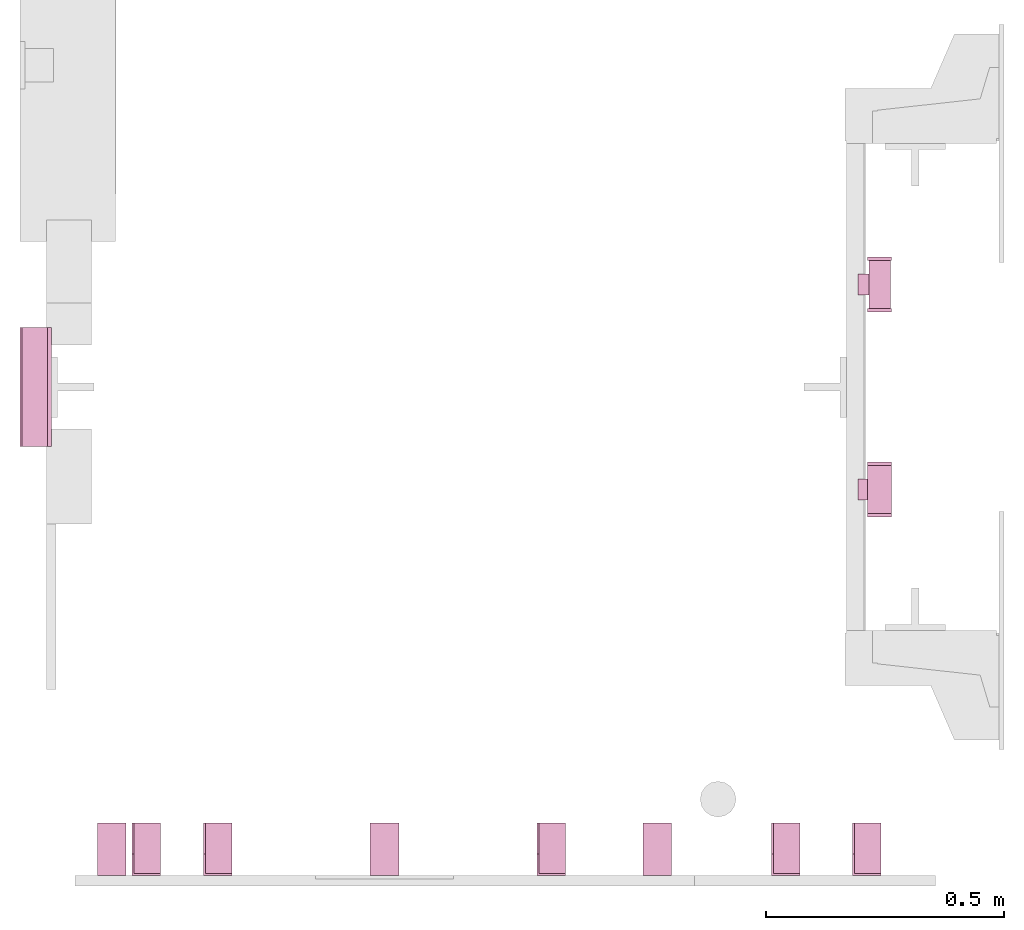
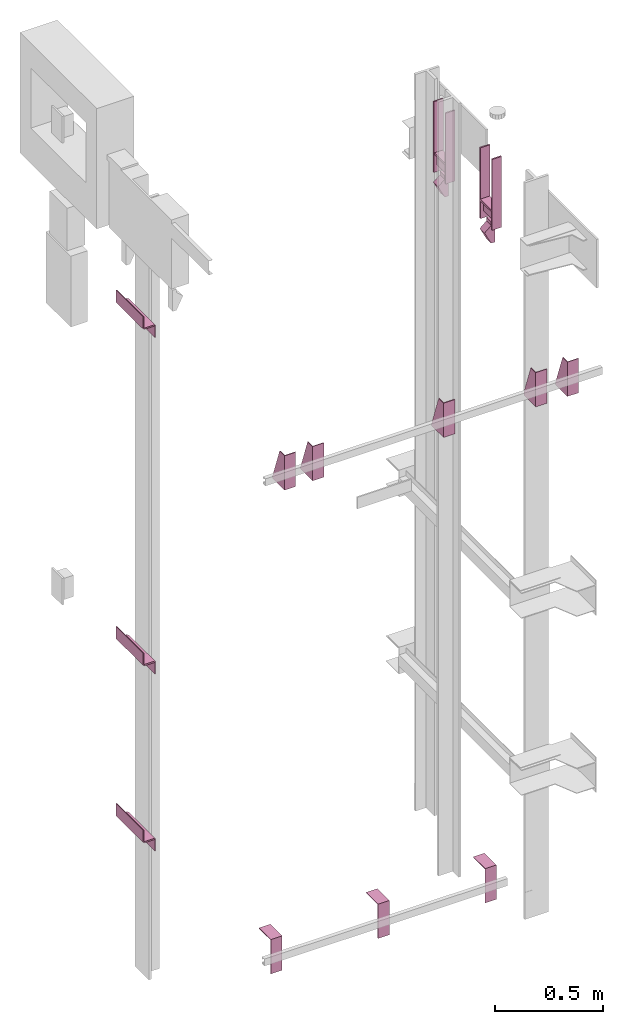
# One storey, part 4 of 4: 12 transport elements.
"""IFC4 building model written with IfcOpenShell, lengths in millimetres."""

from ifc_helpers import new_model, entity, si_unit, converted_unit, frame, origin_with_axes, place, context, subcontext, project, spatial, faceted_brep, element, save


model = new_model("IFC4")

# Units and contexts
context_of_model = context(None, 3, precision=0.01, world=origin_with_axes())
sub_context_1 = subcontext(context_of_model, None, None, "MODEL_VIEW")
sub_context_2 = subcontext(context_of_model, None, None, "MODEL_VIEW")
sub_context_3 = subcontext(context_of_model, None, None, "MODEL_VIEW")
sub_context_4 = subcontext(context_of_model, None, None, "MODEL_VIEW")
sub_context_5 = subcontext(context_of_model, None, None, "MODEL_VIEW")
sub_context_6 = subcontext(context_of_model, None, None, "MODEL_VIEW")
sub_context_7 = subcontext(context_of_model, None, None, "MODEL_VIEW")
sub_context_8 = subcontext(context_of_model, None, None, "MODEL_VIEW")
sub_context_9 = subcontext(context_of_model, None, None, "MODEL_VIEW")
sub_context_10 = subcontext(context_of_model, None, None, "MODEL_VIEW")
sub_context_11 = subcontext(context_of_model, None, None, "MODEL_VIEW")
sub_context_12 = subcontext(context_of_model, None, None, "MODEL_VIEW")
ifc_project = project(units=[converted_unit("PLANEANGLEUNIT", "degree", entity("IfcPlaneAngleMeasure", 0.017453292519943), si_unit("PLANEANGLEUNIT", "RADIAN"), dimensions=[0, 0, 0, 0, 0, 0, 0]), si_unit("LENGTHUNIT", "METRE", prefix="MILLI"), si_unit("MASSUNIT", "GRAM", prefix="KILO"), converted_unit("TIMEUNIT", "year", entity("IfcTimeMeasure", 31557600.0), si_unit("TIMEUNIT", "SECOND"), dimensions=[0, 0, 1, 0, 0, 0, 0]), si_unit("THERMODYNAMICTEMPERATUREUNIT", "DEGREE_CELSIUS"), si_unit("AREAUNIT", "SQUARE_METRE"), si_unit("FORCEUNIT", "NEWTON"), si_unit("VOLUMEUNIT", "CUBIC_METRE"), si_unit("PRESSUREUNIT", "PASCAL"), si_unit("SOLIDANGLEUNIT", "STERADIAN")], contexts=[context_of_model])

# Site, building, storey
site = spatial("IfcSite", under=ifc_project)
building = spatial("IfcBuilding", under=site, Name="Document")
placement = place(None, origin_with_axes())
storey_placement = place(placement, frame((0.0, 0.0, 4420.0), z_axis=(0.0, 0.0, 1.0), x_axis=(1.0, 0.0, 0.0)))
storey = spatial("IfcBuildingStorey", under=building, at=storey_placement, Name="1", Elevation=4420.0)

# Transport elements
transport_element_1_placement = place(storey_placement, frame((1804.0, 810.0, 2854.0), z_axis=(0.0, 0.0, 1.0), x_axis=(1.0, 0.0, 0.0)))
element("IfcTransportElement", 1, at=transport_element_1_placement, inside=storey, PredefinedType="ELEVATOR", context=sub_context_1, shape_type="Brep", body=[
    faceted_brep([(-25.0, 480.0, 100.0), (-25.0, 488.0, 100.0), (25.0, 488.0, 100.0), (25.0, 480.0, 100.0), (-25.0, 480.0, 500.0), (25.0, 480.0, 500.0), (25.0, 488.0, 500.0), (-25.0, 488.0, 500.0)], [[[0, 1, 2, 3]], [[4, 5, 6, 7]], [[0, 3, 5, 4]], [[3, 2, 6, 5]], [[2, 1, 7, 6]], [[1, 0, 4, 7]]]),
    faceted_brep([(10.0, 452.0, 0.0), (10.0, 452.0, 120.0), (10.0, 408.0, 120.0), (10.0, 408.0, 0.0), (-10.0, 408.0, 120.0), (-10.0, 452.0, 120.0), (-10.0, 452.0, 100.0), (-10.0, 408.0, 100.0), (-45.0, 408.0, 70.0), (-45.0, 452.0, 70.0), (-10.0, 452.0, 0.0), (-10.0, 408.0, 0.0)], [[[0, 1, 2, 3]], [[4, 5, 6, 7]], [[8, 9, 10, 11]], [[7, 6, 9, 8]], [[3, 2, 4, 7, 8, 11]], [[9, 6, 5, 1, 0, 10]], [[10, 0, 3, 11]], [[2, 1, 5, 4]]]),
    faceted_brep([(22.5, 480.0, 200.0), (22.5, 480.0, 211.0), (22.5, 380.0, 211.0), (22.5, 380.0, 200.0), (-22.5, 480.0, 200.0), (-22.5, 380.0, 200.0), (-22.5, 380.0, 211.0), (-22.5, 480.0, 211.0)], [[[0, 1, 2, 3]], [[4, 5, 6, 7]], [[0, 3, 5, 4]], [[3, 2, 6, 5]], [[2, 1, 7, 6]], [[1, 0, 4, 7]]]),
    faceted_brep([(25.0, 50.0, 200.0), (25.0, 50.0, 211.0), (25.0, -50.0, 211.0), (25.0, -50.0, 200.0), (-25.0, 50.0, 200.0), (-25.0, -50.0, 200.0), (-25.0, -50.0, 211.0), (-25.0, 50.0, 211.0)], [[[0, 1, 2, 3]], [[4, 5, 6, 7]], [[0, 3, 5, 4]], [[3, 2, 6, 5]], [[2, 1, 7, 6]], [[1, 0, 4, 7]]]),
    faceted_brep([(-25.0, -58.0, 100.0), (-25.0, -50.0, 100.0), (25.0, -50.0, 100.0), (25.0, -58.0, 100.0), (-25.0, -58.0, 500.0), (25.0, -58.0, 500.0), (25.0, -50.0, 500.0), (-25.0, -50.0, 500.0)], [[[0, 1, 2, 3]], [[4, 5, 6, 7]], [[0, 3, 5, 4]], [[3, 2, 6, 5]], [[2, 1, 7, 6]], [[1, 0, 4, 7]]]),
    faceted_brep([(10.0, 480.0, 140.0), (10.0, 480.0, 200.0), (10.0, 380.0, 200.0), (10.0, 380.0, 140.0), (-10.0, 480.0, 140.0), (-10.0, 380.0, 140.0), (-10.0, 380.0, 200.0), (-10.0, 480.0, 200.0)], [[[0, 1, 2, 3]], [[4, 5, 6, 7]], [[0, 3, 5, 4]], [[3, 2, 6, 5]], [[2, 1, 7, 6]], [[1, 0, 4, 7]]]),
    faceted_brep([(10.0, 22.0, 0.0), (10.0, 22.0, 120.0), (10.0, -22.0, 120.0), (10.0, -22.0, 0.0), (-10.0, -22.0, 120.0), (-10.0, 22.0, 120.0), (-10.0, 22.0, 100.0), (-10.0, -22.0, 100.0), (-45.0, -22.0, 70.0), (-45.0, 22.0, 70.0), (-10.0, 22.0, 0.0), (-10.0, -22.0, 0.0)], [[[0, 1, 2, 3]], [[4, 5, 6, 7]], [[8, 9, 10, 11]], [[7, 6, 9, 8]], [[3, 2, 4, 7, 8, 11]], [[9, 6, 5, 1, 0, 10]], [[10, 0, 3, 11]], [[2, 1, 5, 4]]]),
    faceted_brep([(-25.0, 50.0, 100.0), (-25.0, 58.0, 100.0), (25.0, 58.0, 100.0), (25.0, 50.0, 100.0), (-25.0, 50.0, 500.0), (25.0, 50.0, 500.0), (25.0, 58.0, 500.0), (-25.0, 58.0, 500.0)], [[[0, 1, 2, 3]], [[4, 5, 6, 7]], [[0, 3, 5, 4]], [[3, 2, 6, 5]], [[2, 1, 7, 6]], [[1, 0, 4, 7]]]),
    faceted_brep([(-25.0, 372.0, 100.0), (-25.0, 380.0, 100.0), (25.0, 380.0, 100.0), (25.0, 372.0, 100.0), (-25.0, 372.0, 500.0), (25.0, 372.0, 500.0), (25.0, 380.0, 500.0), (-25.0, 380.0, 500.0)], [[[0, 1, 2, 3]], [[4, 5, 6, 7]], [[0, 3, 5, 4]], [[3, 2, 6, 5]], [[2, 1, 7, 6]], [[1, 0, 4, 7]]]),
    faceted_brep([(10.0, 50.0, 140.0), (10.0, 50.0, 200.0), (10.0, -50.0, 200.0), (10.0, -50.0, 140.0), (-10.0, 50.0, 140.0), (-10.0, -50.0, 140.0), (-10.0, -50.0, 200.0), (-10.0, 50.0, 200.0)], [[[0, 1, 2, 3]], [[4, 5, 6, 7]], [[0, 3, 5, 4]], [[3, 2, 6, 5]], [[2, 1, 7, 6]], [[1, 0, 4, 7]]]),
])
transport_element_2_placement = place(storey_placement, frame((265.0, 0.0, 2580.0), z_axis=(0.0, 0.0, 1.0), x_axis=(1.0, 0.0, 0.0)))
element("IfcTransportElement", 2, at=transport_element_2_placement, inside=storey, PredefinedType="ELEVATOR", context=sub_context_2, shape_type="Brep", body=[
    faceted_brep([(-30.0, 0.0, -97.0), (-30.0, 0.0, 97.0), (-30.0, 4.0, 97.0), (-30.0, 4.0, -93.0), (-30.0, 110.0, -93.0), (-30.0, 110.0, -97.0), (30.0, 110.0, -97.0), (30.0, 110.0, -93.0), (30.0, 4.0, -93.0), (30.0, 4.0, 97.0), (30.0, 0.0, 97.0), (30.0, 0.0, -97.0)], [[[0, 1, 2, 3, 4, 5]], [[6, 7, 8, 9, 10, 11]], [[11, 10, 1, 0]], [[2, 9, 8, 3]], [[4, 7, 6, 5]], [[5, 6, 11, 0]], [[8, 7, 4, 3]], [[10, 9, 2, 1]]]),
    faceted_brep([(-30.0, 4.0, -93.0), (-30.0, 4.0, 97.0), (-30.0, 45.0, 97.0), (-30.0, 110.0, -82.0), (-30.0, 110.0, -93.0), (-26.0, 4.0, -93.0), (-26.0, 110.0, -93.0), (-26.0, 110.0, -82.0), (-26.0, 45.0, 97.0), (-26.0, 4.0, 97.0)], [[[0, 1, 2, 3, 4]], [[5, 6, 7, 8, 9]], [[5, 0, 4, 6]], [[6, 4, 3, 7]], [[7, 3, 2, 8]], [[8, 2, 1, 9]], [[9, 1, 0, 5]]]),
])
transport_element_3_placement = place(storey_placement, frame((415.0, 0.0, 2580.0), z_axis=(0.0, 0.0, 1.0), x_axis=(1.0, 0.0, 0.0)))
element("IfcTransportElement", 3, at=transport_element_3_placement, inside=storey, PredefinedType="ELEVATOR", context=sub_context_3, shape_type="Brep", body=[
    faceted_brep([(-30.0, 0.0, -97.0), (-30.0, 0.0, 97.0), (-30.0, 4.0, 97.0), (-30.0, 4.0, -93.0), (-30.0, 110.0, -93.0), (-30.0, 110.0, -97.0), (30.0, 110.0, -97.0), (30.0, 110.0, -93.0), (30.0, 4.0, -93.0), (30.0, 4.0, 97.0), (30.0, 0.0, 97.0), (30.0, 0.0, -97.0)], [[[0, 1, 2, 3, 4, 5]], [[6, 7, 8, 9, 10, 11]], [[11, 10, 1, 0]], [[2, 9, 8, 3]], [[4, 7, 6, 5]], [[5, 6, 11, 0]], [[8, 7, 4, 3]], [[10, 9, 2, 1]]]),
    faceted_brep([(-30.0, 4.0, -93.0), (-30.0, 4.0, 97.0), (-30.0, 45.0, 97.0), (-30.0, 110.0, -82.0), (-30.0, 110.0, -93.0), (-26.0, 4.0, -93.0), (-26.0, 110.0, -93.0), (-26.0, 110.0, -82.0), (-26.0, 45.0, 97.0), (-26.0, 4.0, 97.0)], [[[0, 1, 2, 3, 4]], [[5, 6, 7, 8, 9]], [[5, 0, 4, 6]], [[6, 4, 3, 7]], [[7, 3, 2, 8]], [[8, 2, 1, 9]], [[9, 1, 0, 5]]]),
])
transport_element_4_placement = place(storey_placement, frame((1115.0, 0.0, 2580.0), z_axis=(0.0, 0.0, 1.0), x_axis=(1.0, 0.0, 0.0)))
element("IfcTransportElement", 4, at=transport_element_4_placement, inside=storey, PredefinedType="ELEVATOR", context=sub_context_4, shape_type="Brep", body=[
    faceted_brep([(-30.0, 4.0, -93.0), (-30.0, 4.0, 97.0), (-30.0, 45.0, 97.0), (-30.0, 110.0, -82.0), (-30.0, 110.0, -93.0), (-26.0, 4.0, -93.0), (-26.0, 110.0, -93.0), (-26.0, 110.0, -82.0), (-26.0, 45.0, 97.0), (-26.0, 4.0, 97.0)], [[[0, 1, 2, 3, 4]], [[5, 6, 7, 8, 9]], [[5, 0, 4, 6]], [[6, 4, 3, 7]], [[7, 3, 2, 8]], [[8, 2, 1, 9]], [[9, 1, 0, 5]]]),
    faceted_brep([(-30.0, 0.0, -97.0), (-30.0, 0.0, 97.0), (-30.0, 4.0, 97.0), (-30.0, 4.0, -93.0), (-30.0, 110.0, -93.0), (-30.0, 110.0, -97.0), (30.0, 110.0, -97.0), (30.0, 110.0, -93.0), (30.0, 4.0, -93.0), (30.0, 4.0, 97.0), (30.0, 0.0, 97.0), (30.0, 0.0, -97.0)], [[[0, 1, 2, 3, 4, 5]], [[6, 7, 8, 9, 10, 11]], [[11, 10, 1, 0]], [[2, 9, 8, 3]], [[4, 7, 6, 5]], [[5, 6, 11, 0]], [[8, 7, 4, 3]], [[10, 9, 2, 1]]]),
])
transport_element_5_placement = place(storey_placement, frame((1607.0, 0.0, 2580.0), z_axis=(0.0, 0.0, 1.0), x_axis=(1.0, 0.0, 0.0)))
element("IfcTransportElement", 5, at=transport_element_5_placement, inside=storey, PredefinedType="ELEVATOR", context=sub_context_5, shape_type="Brep", body=[
    faceted_brep([(-30.0, 4.0, -93.0), (-30.0, 4.0, 97.0), (-30.0, 45.0, 97.0), (-30.0, 110.0, -82.0), (-30.0, 110.0, -93.0), (-26.0, 4.0, -93.0), (-26.0, 110.0, -93.0), (-26.0, 110.0, -82.0), (-26.0, 45.0, 97.0), (-26.0, 4.0, 97.0)], [[[0, 1, 2, 3, 4]], [[5, 6, 7, 8, 9]], [[5, 0, 4, 6]], [[6, 4, 3, 7]], [[7, 3, 2, 8]], [[8, 2, 1, 9]], [[9, 1, 0, 5]]]),
    faceted_brep([(-30.0, 0.0, -97.0), (-30.0, 0.0, 97.0), (-30.0, 4.0, 97.0), (-30.0, 4.0, -93.0), (-30.0, 110.0, -93.0), (-30.0, 110.0, -97.0), (30.0, 110.0, -97.0), (30.0, 110.0, -93.0), (30.0, 4.0, -93.0), (30.0, 4.0, 97.0), (30.0, 0.0, 97.0), (30.0, 0.0, -97.0)], [[[0, 1, 2, 3, 4, 5]], [[6, 7, 8, 9, 10, 11]], [[11, 10, 1, 0]], [[2, 9, 8, 3]], [[4, 7, 6, 5]], [[5, 6, 11, 0]], [[8, 7, 4, 3]], [[10, 9, 2, 1]]]),
])
transport_element_6_placement = place(storey_placement, frame((1777.0, 0.0, 2580.0), z_axis=(0.0, 0.0, 1.0), x_axis=(1.0, 0.0, 0.0)))
element("IfcTransportElement", 6, at=transport_element_6_placement, inside=storey, PredefinedType="ELEVATOR", context=sub_context_6, shape_type="Brep", body=[
    faceted_brep([(-30.0, 4.0, -93.0), (-30.0, 4.0, 97.0), (-30.0, 45.0, 97.0), (-30.0, 110.0, -82.0), (-30.0, 110.0, -93.0), (-26.0, 4.0, -93.0), (-26.0, 110.0, -93.0), (-26.0, 110.0, -82.0), (-26.0, 45.0, 97.0), (-26.0, 4.0, 97.0)], [[[0, 1, 2, 3, 4]], [[5, 6, 7, 8, 9]], [[5, 0, 4, 6]], [[6, 4, 3, 7]], [[7, 3, 2, 8]], [[8, 2, 1, 9]], [[9, 1, 0, 5]]]),
    faceted_brep([(-30.0, 0.0, -97.0), (-30.0, 0.0, 97.0), (-30.0, 4.0, 97.0), (-30.0, 4.0, -93.0), (-30.0, 110.0, -93.0), (-30.0, 110.0, -97.0), (30.0, 110.0, -97.0), (30.0, 110.0, -93.0), (30.0, 4.0, -93.0), (30.0, 4.0, 97.0), (30.0, 0.0, 97.0), (30.0, 0.0, -97.0)], [[[0, 1, 2, 3, 4, 5]], [[6, 7, 8, 9, 10, 11]], [[11, 10, 1, 0]], [[2, 9, 8, 3]], [[4, 7, 6, 5]], [[5, 6, 11, 0]], [[8, 7, 4, 3]], [[10, 9, 2, 1]]]),
])
transport_element_7_placement = place(storey_placement, frame((1337.5, 0.0, -30.0), z_axis=(0.0, 0.0, -1.0), x_axis=(-1.0, 0.0, 0.0)))
element("IfcTransportElement", 7, at=transport_element_7_placement, inside=storey, PredefinedType="ELEVATOR", context=sub_context_7, shape_type="Brep", body=[
    faceted_brep([(30.0, 0.0, 0.0), (30.0, 110.0, 0.0), (30.0, 110.0, 4.0), (30.0, 4.0, 4.0), (30.0, 4.0, 194.0), (30.0, 0.0, 194.0), (-30.0, 4.0, 194.0), (-30.0, 4.0, 4.0), (-30.0, 110.0, 4.0), (-30.0, 110.0, 0.0), (-30.0, 0.0, 0.0), (-30.0, 0.0, 194.0)], [[[0, 1, 2, 3, 4, 5]], [[6, 7, 8, 9, 10, 11]], [[11, 10, 0, 5]], [[3, 7, 6, 4]], [[1, 9, 8, 2]], [[4, 6, 11, 5]], [[10, 9, 1, 0]], [[2, 8, 7, 3]]]),
    faceted_brep([(-30.0, 4.0, 4.0), (-30.0, 4.0, 194.0), (-30.0, 45.0, 194.0), (-30.0, 110.0, 15.0), (-30.0, 110.0, 4.0), (-26.0, 4.0, 4.0), (-26.0, 110.0, 4.0), (-26.0, 110.0, 15.0), (-26.0, 45.0, 194.0), (-26.0, 4.0, 194.0)], [[[0, 1, 2, 3, 4]], [[5, 6, 7, 8, 9]], [[5, 0, 4, 6]], [[6, 4, 3, 7]], [[7, 3, 2, 8]], [[8, 2, 1, 9]], [[9, 1, 0, 5]]]),
])
transport_element_8_placement = place(storey_placement, frame((765.0, 0.0, -30.0), z_axis=(0.0, 0.0, -1.0), x_axis=(-1.0, 0.0, 0.0)))
element("IfcTransportElement", 8, at=transport_element_8_placement, inside=storey, PredefinedType="ELEVATOR", context=sub_context_8, shape_type="Brep", body=[
    faceted_brep([(-30.0, 4.0, 4.0), (-30.0, 4.0, 194.0), (-30.0, 45.0, 194.0), (-30.0, 110.0, 15.0), (-30.0, 110.0, 4.0), (-26.0, 4.0, 4.0), (-26.0, 110.0, 4.0), (-26.0, 110.0, 15.0), (-26.0, 45.0, 194.0), (-26.0, 4.0, 194.0)], [[[0, 1, 2, 3, 4]], [[5, 6, 7, 8, 9]], [[5, 0, 4, 6]], [[6, 4, 3, 7]], [[7, 3, 2, 8]], [[8, 2, 1, 9]], [[9, 1, 0, 5]]]),
    faceted_brep([(30.0, 0.0, 0.0), (30.0, 110.0, 0.0), (30.0, 110.0, 4.0), (30.0, 4.0, 4.0), (30.0, 4.0, 194.0), (30.0, 0.0, 194.0), (-30.0, 4.0, 194.0), (-30.0, 4.0, 4.0), (-30.0, 110.0, 4.0), (-30.0, 110.0, 0.0), (-30.0, 0.0, 0.0), (-30.0, 0.0, 194.0)], [[[0, 1, 2, 3, 4, 5]], [[6, 7, 8, 9, 10, 11]], [[11, 10, 0, 5]], [[3, 7, 6, 4]], [[1, 9, 8, 2]], [[4, 6, 11, 5]], [[10, 9, 1, 0]], [[2, 8, 7, 3]]]),
])
transport_element_9_placement = place(storey_placement, frame((192.5, 0.0, -30.0), z_axis=(0.0, 0.0, -1.0), x_axis=(-1.0, 0.0, 0.0)))
element("IfcTransportElement", 9, at=transport_element_9_placement, inside=storey, PredefinedType="ELEVATOR", context=sub_context_9, shape_type="Brep", body=[
    faceted_brep([(30.0, 0.0, 0.0), (30.0, 110.0, 0.0), (30.0, 110.0, 4.0), (30.0, 4.0, 4.0), (30.0, 4.0, 194.0), (30.0, 0.0, 194.0), (-30.0, 4.0, 194.0), (-30.0, 4.0, 4.0), (-30.0, 110.0, 4.0), (-30.0, 110.0, 0.0), (-30.0, 0.0, 0.0), (-30.0, 0.0, 194.0)], [[[0, 1, 2, 3, 4, 5]], [[6, 7, 8, 9, 10, 11]], [[11, 10, 0, 5]], [[3, 7, 6, 4]], [[1, 9, 8, 2]], [[4, 6, 11, 5]], [[10, 9, 1, 0]], [[2, 8, 7, 3]]]),
    faceted_brep([(-30.0, 4.0, 4.0), (-30.0, 4.0, 194.0), (-30.0, 45.0, 194.0), (-30.0, 110.0, 15.0), (-30.0, 110.0, 4.0), (-26.0, 4.0, 4.0), (-26.0, 110.0, 4.0), (-26.0, 110.0, 15.0), (-26.0, 45.0, 194.0), (-26.0, 4.0, 194.0)], [[[0, 1, 2, 3, 4]], [[5, 6, 7, 8, 9]], [[5, 0, 4, 6]], [[6, 4, 3, 7]], [[7, 3, 2, 8]], [[8, 2, 1, 9]], [[9, 1, 0, 5]]]),
])
transport_element_10_placement = place(storey_placement, frame((0.0, 1025.0, 64.0), z_axis=(0.0, 0.0, 1.0), x_axis=(0.0, -1.0, 0.0)))
element("IfcTransportElement", 10, at=transport_element_10_placement, inside=storey, PredefinedType="ELEVATOR", context=sub_context_10, shape_type="Brep", body=[
    faceted_brep([(125.0, 8.0, -35.0), (-125.0, 8.0, -35.0), (-125.0, 8.0, -39.0), (125.0, 8.0, -39.0), (125.0, 62.0, -39.0), (-125.0, 62.0, -39.0), (-125.0, 62.0, -105.0), (125.0, 62.0, -105.0), (-125.0, 66.0, -105.0), (-125.0, 66.0, -35.0), (125.0, 66.0, -35.0), (125.0, 66.0, -105.0)], [[[0, 1, 2, 3]], [[4, 5, 6, 7]], [[8, 9, 10, 11]], [[4, 7, 11, 10, 0, 3]], [[1, 9, 8, 6, 5, 2]], [[2, 5, 4, 3]], [[10, 9, 1, 0]], [[6, 8, 11, 7]]]),
    faceted_brep([(125.0, 0.0, 35.0), (-125.0, 0.0, 35.0), (-125.0, 0.0, -35.0), (125.0, 0.0, -35.0), (-125.0, 4.0, -31.0), (-125.0, 4.0, 35.0), (125.0, 4.0, 35.0), (125.0, 4.0, -31.0), (-125.0, 58.0, -35.0), (-125.0, 58.0, -31.0), (125.0, 58.0, -31.0), (125.0, 58.0, -35.0)], [[[0, 1, 2, 3]], [[4, 5, 6, 7]], [[8, 9, 10, 11]], [[11, 10, 7, 6, 0, 3]], [[2, 1, 5, 4, 9, 8]], [[2, 8, 11, 3]], [[10, 9, 4, 7]], [[6, 5, 1, 0]]]),
])
transport_element_11_placement = place(storey_placement, frame((0.0, 1025.0, 1064.0), z_axis=(0.0, 0.0, 1.0), x_axis=(0.0, -1.0, 0.0)))
element("IfcTransportElement", 11, at=transport_element_11_placement, inside=storey, PredefinedType="ELEVATOR", context=sub_context_11, shape_type="Brep", body=[
    faceted_brep([(125.0, 8.0, -35.0), (-125.0, 8.0, -35.0), (-125.0, 8.0, -39.0), (125.0, 8.0, -39.0), (125.0, 62.0, -39.0), (-125.0, 62.0, -39.0), (-125.0, 62.0, -105.0), (125.0, 62.0, -105.0), (-125.0, 66.0, -105.0), (-125.0, 66.0, -35.0), (125.0, 66.0, -35.0), (125.0, 66.0, -105.0)], [[[0, 1, 2, 3]], [[4, 5, 6, 7]], [[8, 9, 10, 11]], [[4, 7, 11, 10, 0, 3]], [[1, 9, 8, 6, 5, 2]], [[2, 5, 4, 3]], [[10, 9, 1, 0]], [[6, 8, 11, 7]]]),
    faceted_brep([(125.0, 0.0, 35.0), (-125.0, 0.0, 35.0), (-125.0, 0.0, -35.0), (125.0, 0.0, -35.0), (-125.0, 4.0, -31.0), (-125.0, 4.0, 35.0), (125.0, 4.0, 35.0), (125.0, 4.0, -31.0), (-125.0, 58.0, -35.0), (-125.0, 58.0, -31.0), (125.0, 58.0, -31.0), (125.0, 58.0, -35.0)], [[[0, 1, 2, 3]], [[4, 5, 6, 7]], [[8, 9, 10, 11]], [[11, 10, 7, 6, 0, 3]], [[2, 1, 5, 4, 9, 8]], [[2, 8, 11, 3]], [[10, 9, 4, 7]], [[6, 5, 1, 0]]]),
])
transport_element_12_placement = place(storey_placement, frame((0.0, 1025.0, 2964.0), z_axis=(0.0, 0.0, 1.0), x_axis=(0.0, -1.0, 0.0)))
element("IfcTransportElement", 12, at=transport_element_12_placement, inside=storey, PredefinedType="ELEVATOR", context=sub_context_12, shape_type="Brep", body=[
    faceted_brep([(125.0, 8.0, -35.0), (-125.0, 8.0, -35.0), (-125.0, 8.0, -39.0), (125.0, 8.0, -39.0), (125.0, 62.0, -39.0), (-125.0, 62.0, -39.0), (-125.0, 62.0, -105.0), (125.0, 62.0, -105.0), (-125.0, 66.0, -105.0), (-125.0, 66.0, -35.0), (125.0, 66.0, -35.0), (125.0, 66.0, -105.0)], [[[0, 1, 2, 3]], [[4, 5, 6, 7]], [[8, 9, 10, 11]], [[4, 7, 11, 10, 0, 3]], [[1, 9, 8, 6, 5, 2]], [[2, 5, 4, 3]], [[10, 9, 1, 0]], [[6, 8, 11, 7]]]),
    faceted_brep([(125.0, 0.0, 35.0), (-125.0, 0.0, 35.0), (-125.0, 0.0, -35.0), (125.0, 0.0, -35.0), (-125.0, 4.0, -31.0), (-125.0, 4.0, 35.0), (125.0, 4.0, 35.0), (125.0, 4.0, -31.0), (-125.0, 58.0, -35.0), (-125.0, 58.0, -31.0), (125.0, 58.0, -31.0), (125.0, 58.0, -35.0)], [[[0, 1, 2, 3]], [[4, 5, 6, 7]], [[8, 9, 10, 11]], [[11, 10, 7, 6, 0, 3]], [[2, 1, 5, 4, 9, 8]], [[2, 8, 11, 3]], [[10, 9, 4, 7]], [[6, 5, 1, 0]]]),
])

save(model, "model.ifc")
